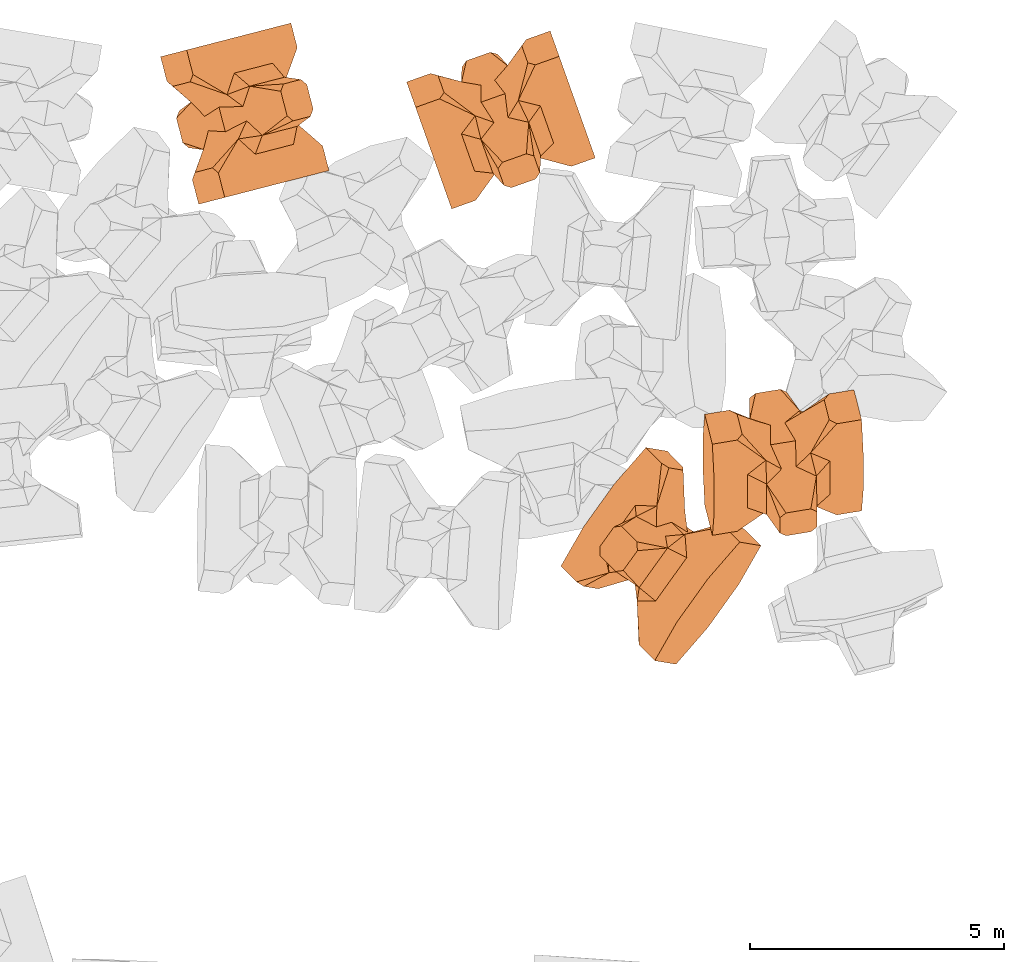
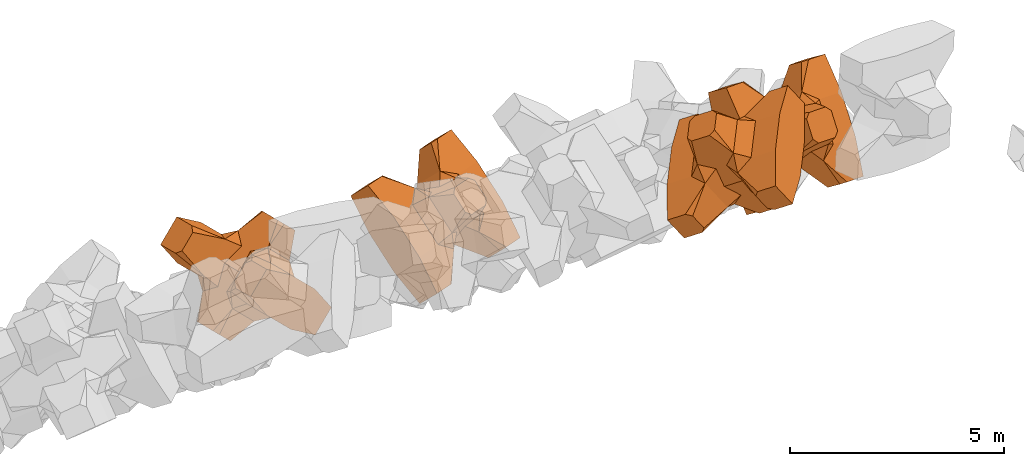
# One storey, part 15 of 17: 4 civil elements.
"""IFC4 building model written with IfcOpenShell, lengths in metres."""

import ifcopenshell
import ifcopenshell.guid

model = None  # the IFC model being written
_history = None  # IfcOwnerHistory: only IFC2X3 demands one
_inside = {}  # id of a spatial element -> (the spatial element, [elements in it])
_under = {}  # id of a project, library or spatial element -> (it, [spatial elements below it])
_declared = {}  # id of a project -> (the project, [libraries it declares])
_typed = {}  # id of a type object -> (the type object, [elements of that type])
_made_of = {}  # id of a material, layer set ... -> (it, [elements and type objects made of it])


def new_model(schema):
    """Start an empty IFC model of exactly this schema.

    Asked for "IFC4X3", IfcOpenShell would pick the latest addendum, in which some entities
    have other attributes; the version numbers below select the first issue.
    IFC2X3 requires an IfcOwnerHistory on every rooted entity: one is made here for all.
    """
    global model, _history
    if schema == "IFC4X3":
        model = ifcopenshell.file(schema_version=(4, 3, 0, 0))
    else:
        model = ifcopenshell.file(schema=schema)
    _inside.clear()
    _under.clear()
    _declared.clear()
    _typed.clear()
    _made_of.clear()
    _history = None
    if model.schema == "IFC2X3":
        org = make("IfcOrganization", Name="unknown")
        user = make(
            "IfcPersonAndOrganization",
            ThePerson=make("IfcPerson", FamilyName="unknown"),
            TheOrganization=org,
        )
        app = make(
            "IfcApplication",
            ApplicationDeveloper=org,
            Version="unknown",
            ApplicationFullName="unknown",
            ApplicationIdentifier="unknown",
        )
        _history = make(
            "IfcOwnerHistory",
            OwningUser=user,
            OwningApplication=app,
            ChangeAction="ADDED",
            CreationDate=0,
        )
    return model


def make(cls, **values):
    """One entity of the class cls with the attributes given. An attribute that is None is left unset."""
    return model.create_entity(
        cls, **{name: value for name, value in values.items() if value is not None}
    )


def entity(cls, *values):
    """Any entity or typed value of the class cls, its attributes in the order of the schema. None: left unset."""
    e = model.create_entity(cls)
    for i, value in enumerate(values):
        if value is not None:
            e[i] = value
    return e


def rooted(cls, **values):
    """An entity with a GlobalId (a new one), such as an element, a storey or a relation."""
    return make(cls, GlobalId=ifcopenshell.guid.new(), OwnerHistory=_history, **values)


def si_unit(unit_type, name, prefix=None):
    """IfcSIUnit, for example si_unit("LENGTHUNIT", "METRE", prefix="MILLI")."""
    return make("IfcSIUnit", UnitType=unit_type, Prefix=prefix, Name=name)


def converted_unit(unit_type, name, factor, base, dimensions=None, offset=None):
    """IfcConversionBasedUnit, such as the inch: factor (a typed value) times the base unit."""
    return make(
        "IfcConversionBasedUnit"
        if offset is None
        else "IfcConversionBasedUnitWithOffset",
        ConversionOffset=offset,
        Dimensions=None
        if dimensions is None
        else entity("IfcDimensionalExponents", *dimensions),
        UnitType=unit_type,
        Name=name,
        ConversionFactor=make(
            "IfcMeasureWithUnit", ValueComponent=factor, UnitComponent=base
        ),
    )


def assignment(units):
    """IfcUnitAssignment: the units of a project."""
    return None if units is None else make("IfcUnitAssignment", Units=units)


def point(xyz):
    """IfcCartesianPoint."""
    return None if xyz is None else make("IfcCartesianPoint", Coordinates=xyz)


def direction(xyz):
    """IfcDirection."""
    return None if xyz is None else make("IfcDirection", DirectionRatios=xyz)


def frame(location, z_axis=None, x_axis=None):
    """IfcAxis2Placement3D, a coordinate frame: its origin and axes. An axis left out is left unset."""
    return make(
        "IfcAxis2Placement3D",
        Location=point(location),
        Axis=direction(z_axis),
        RefDirection=direction(x_axis),
    )


def frame_2d(location, x_axis=None):
    """IfcAxis2Placement2D, a coordinate frame in the plane: its origin and x axis."""
    return make(
        "IfcAxis2Placement2D", Location=point(location), RefDirection=direction(x_axis)
    )


def origin_with_axes():
    """The frame at (0, 0, 0) with the z axis (0, 0, 1) and the x axis (1, 0, 0) written out."""
    return frame((0.0, 0.0, 0.0), z_axis=(0.0, 0.0, 1.0), x_axis=(1.0, 0.0, 0.0))


def origin_2d_with_axis():
    """The frame at (0, 0) in the plane with the x axis (1, 0) written out."""
    return frame_2d((0.0, 0.0), x_axis=(1.0, 0.0))


def place(relative_to, where):
    """IfcLocalPlacement: puts the frame where relative to a parent placement (None: the world)."""
    return make(
        "IfcLocalPlacement", PlacementRelTo=relative_to, RelativePlacement=where
    )


def context(
    kind, dimensions, precision=None, world=None, true_north=None, identifier=None
):
    """IfcGeometricRepresentationContext, for example the 3D "Model" context."""
    return make(
        "IfcGeometricRepresentationContext",
        ContextIdentifier=identifier,
        ContextType=kind,
        CoordinateSpaceDimension=dimensions,
        Precision=precision,
        WorldCoordinateSystem=world,
        TrueNorth=true_north,
    )


def subcontext(parent, identifier, kind, view, scale=None):
    """IfcGeometricRepresentationSubContext, for example "Body" below "Model"."""
    return make(
        "IfcGeometricRepresentationSubContext",
        ContextIdentifier=identifier,
        ContextType=kind,
        ParentContext=parent,
        TargetScale=scale,
        TargetView=view,
    )


def project(units=None, contexts=None):
    """IfcProject with its units and contexts."""
    return rooted(
        "IfcProject",
        Name="project",
        RepresentationContexts=contexts,
        UnitsInContext=assignment(units),
    )


def spatial(cls, under=None, at=None, **own):
    """A site, building, storey or space (cls), placed at a placement, below another one or the project."""
    s = rooted(cls, ObjectPlacement=at, **own)
    if under is not None:
        _under.setdefault(under.id(), (under, []))[1].append(s)
    return s


def point_list(points):
    """IfcCartesianPointList2D or 3D."""
    cls = (
        "IfcCartesianPointList2D" if len(points[0]) == 2 else "IfcCartesianPointList3D"
    )
    return make(cls, CoordList=points)


def polygons(points, faces, closed=None, point_numbers=None):
    """IfcPolygonalFaceSet: a face is its outer loop, then its inner loops; points numbered from 1."""
    made = []
    for loops in faces:
        if len(loops) == 1:
            made.append(make("IfcIndexedPolygonalFace", CoordIndex=loops[0]))
        else:
            made.append(
                make(
                    "IfcIndexedPolygonalFaceWithVoids",
                    CoordIndex=loops[0],
                    InnerCoordIndices=loops[1:],
                )
            )
    return make(
        "IfcPolygonalFaceSet",
        Coordinates=point_list(points),
        Closed=closed,
        Faces=made,
        PnIndex=point_numbers,
    )


def shape(context_of_items, identifier, shape_type, items):
    """IfcShapeRepresentation: the items that make up one representation, for example the "Body"."""
    return make(
        "IfcShapeRepresentation",
        ContextOfItems=context_of_items,
        RepresentationIdentifier=identifier,
        RepresentationType=shape_type,
        Items=items,
    )


def made_of(thing, what):
    """Note that an element or type object is made of a material, layer set ...; save() writes the relation."""
    if what is not None:
        _made_of.setdefault(what.id(), (what, []))[1].append(thing)
    return thing


def element(
    cls,
    number,
    at=None,
    inside=None,
    cuts=None,
    type_object=None,
    material=None,
    context=None,
    identifier="Body",
    shape_type=None,
    held_by="IfcProductDefinitionShape",
    body=None,
    shapes=None,
    **own,
):
    """One element of the class cls, such as IfcWall. Its Tag is "e" and its number.

    at: its placement. inside: the storey or other place that contains it. cuts: it is an
    opening in that element (IfcRelVoidsElement). A single representation is given by context,
    identifier, shape_type and body (its items); several are given by shapes. held_by: the class
    of the entity that holds the representations. save() writes the other relations.
    """
    e = rooted(cls, Tag="e%d" % number, ObjectPlacement=at, **own)
    if body is not None:
        shapes = [shape(context, identifier, shape_type, body)]
    if shapes is not None:
        e.Representation = make(held_by, Representations=shapes)
    if inside is not None:
        _inside.setdefault(inside.id(), (inside, []))[1].append(e)
    if cuts is not None:
        rooted(
            "IfcRelVoidsElement", RelatingBuildingElement=cuts, RelatedOpeningElement=e
        )
    if type_object is not None:
        _typed.setdefault(type_object.id(), (type_object, []))[1].append(e)
    return made_of(e, material)


def aggregate(whole, parts):
    """IfcRelAggregates: a whole, such as a stair, and the parts it consists of."""
    return rooted("IfcRelAggregates", RelatingObject=whole, RelatedObjects=parts)


def save(model, path):
    """Write the relations noted so far, then the file.

    IfcRelAggregates (storeys below a building ...), IfcRelContainedInSpatialStructure (elements
    in a storey), IfcRelDefinesByType, IfcRelAssociatesMaterial and IfcRelDeclares: one each for
    every whole, place, type object, material and project.
    """
    for whole, parts in _under.values():
        aggregate(whole, parts)
    for where, things in _inside.values():
        rooted(
            "IfcRelContainedInSpatialStructure",
            RelatedElements=things,
            RelatingStructure=where,
        )
    for kind, things in _typed.values():
        rooted("IfcRelDefinesByType", RelatedObjects=things, RelatingType=kind)
    for what, things in _made_of.values():
        rooted("IfcRelAssociatesMaterial", RelatedObjects=things, RelatingMaterial=what)
    for by, libraries in _declared.values():
        rooted("IfcRelDeclares", RelatingContext=by, RelatedDefinitions=libraries)
    model.write(path)


model = new_model("IFC4")

# Units and contexts
model_context = context("Model", 3, precision=1e-05, world=origin_with_axes())
plan_context = context("Plan", 2, precision=1e-05, world=origin_2d_with_axis())
body_context = subcontext(model_context, "Body", "Model", "MODEL_VIEW")
ifc_project = project(units=[si_unit("VOLUMEUNIT", "CUBIC_METRE"), si_unit("LENGTHUNIT", "METRE"), converted_unit("PLANEANGLEUNIT", "degree", entity("IfcReal", 0.0174532925199433), si_unit("PLANEANGLEUNIT", "RADIAN"), dimensions=[0, 0, 0, 0, 0, 0, 0]), si_unit("AREAUNIT", "SQUARE_METRE")], contexts=[model_context, plan_context])

# Site, building, storey
site_placement = place(None, origin_with_axes())
site = spatial("IfcSite", under=ifc_project, at=site_placement)
building_placement = place(site_placement, origin_with_axes())
building = spatial("IfcBuilding", under=site, at=building_placement, Name="Building")
storey_placement = place(building_placement, origin_with_axes())
storey = spatial("IfcBuildingStorey", under=building, at=storey_placement, Name="Storey")

# Civil elements
civil_element_1_placement = place(storey_placement, frame((10.4980764389038, 20.5367698669434, 2.36640000343323), z_axis=(-0.685017216108245, -0.176812213537438, -0.706745254514879), x_axis=(-0.684317272957764, -0.176631565261449, 0.707468133618003)))
element("IfcCivilElement", 1, at=civil_element_1_placement, inside=storey, ObjectType="IfcCivilElementType", context=body_context, shape_type="Tessellation", body=[
    polygons([(0.50000011920929, 0.500000059604645, 0.821428656578064), (0.374999821186066, 0.249999940395355, 1.5), (0.550000011920929, 0.145680621266365, 0.550000071525574), (0.374999821186066, -0.250000029802322, 1.5), (0.651315808296204, -0.250000029802322, 1.45970545872842e-07), (0.651315808296204, 0.249999940395355, 1.45970545872842e-07), (0.550000011920929, -0.145680695772171, 0.550000071525574), (0.50000011920929, -0.500000059604645, 0.821428656578064), (-0.25, 0.374999791383743, 1.5), (0.249999970197678, 0.374999791383743, 1.5), (-0.500000059604645, 0.500000059604645, 0.821428656578064), (-0.550000011920929, 0.824999988079071, 0.550000071525574), (0.550000011920929, 0.824999988079071, 0.550000071525574), (-0.550000011920929, 1.5, 0.550000071525574), (0.550000011920929, 1.5, 0.550000071525574), (-0.25, -0.375, 1.5), (0.249999970197678, -0.375, 1.5), (-0.374999970197678, -0.250000029802322, 1.5), (-0.374999970197678, 0.249999940395355, 1.5), (1.5, 0.87499988079071, -0.249999806284904), (1.5, 0.87499988079071, 0.25000011920929), (0.845557510852814, 0.449999898672104, -0.495555102825165), (0.845557510852814, 0.449999898672104, 0.495555102825165), (1.5, 1.5, -0.374999791383743), (1.5, 1.5, 0.374999940395355), (1.5, 1.0, -0.374999791383743), (1.5, 1.0, 0.374999940395355), (-1.5, 1.5, -0.374999791383743), (-1.5, 1.5, 0.374999940395355), (-0.550000011920929, 1.5, -0.54999977350235), (0.550000011920929, 1.5, -0.54999977350235), (0.550000011920929, 0.145680621266365, -0.54999977350235), (-0.500000059604645, -0.500000059604645, 0.821428656578064), (-0.550000011920929, -0.145680695772171, 0.550000071525574), (-0.651315808296204, 0.249999940395355, 1.45970545872842e-07), (-0.651315808296204, -0.250000029802322, 1.45970545872842e-07), (-0.550000011920929, 0.145680621266365, 0.550000071525574), (-1.5, 0.87499988079071, 0.25000011920929), (-1.5, 0.87499988079071, -0.249999806284904), (-0.845557391643524, 0.449999898672104, 0.495555102825165), (-0.845557391643524, 0.449999898672104, -0.495555102825165), (-1.5, 1.0, 0.374999940395355), (-1.5, 1.0, -0.374999791383743), (-0.550000011920929, 0.145680621266365, -0.54999977350235), (0.550000011920929, -0.825000107288361, 0.550000071525574), (-0.550000011920929, -0.825000107288361, 0.550000071525574), (0.550000011920929, -1.5, 0.550000071525574), (-0.550000011920929, -1.5, 0.550000071525574), (1.5, -0.875000059604645, 0.25000011920929), (1.5, -0.875000059604645, -0.249999806284904), (0.845557510852814, -0.450000137090683, 0.495555102825165), (0.845557510852814, -0.450000137090683, -0.495555102825165), (1.5, -1.5, 0.374999940395355), (1.5, -1.5, -0.374999791383743), (1.5, -1.00000011920929, 0.374999940395355), (1.5, -1.00000011920929, -0.374999791383743), (0.550000011920929, -1.5, -0.54999977350235), (-0.550000011920929, -1.5, -0.54999977350235), (-1.5, -1.5, -0.374999791383743), (-1.5, -1.5, 0.374999940395355), (0.550000011920929, -0.145680695772171, -0.54999977350235), (-1.5, -0.875000059604645, -0.249999806284904), (-1.5, -0.875000059604645, 0.25000011920929), (-0.845557391643524, -0.450000137090683, -0.495555102825165), (-0.845557391643524, -0.450000137090683, 0.495555102825165), (-1.5, -1.00000011920929, -0.374999791383743), (-1.5, -1.00000011920929, 0.374999940395355), (-0.550000011920929, -0.145680695772171, -0.54999977350235), (0.50000011920929, -0.500000059604645, -0.821428418159485), (0.374999821186066, -0.250000029802322, -1.49999976158142), (0.374999821186066, 0.249999940395355, -1.49999976158142), (0.50000011920929, 0.500000059604645, -0.821428418159485), (0.249999970197678, 0.374999791383743, -1.49999976158142), (-0.25, 0.374999791383743, -1.49999976158142), (-0.500000059604645, 0.500000059604645, -0.821428418159485), (0.550000011920929, 0.824999988079071, -0.54999977350235), (-0.550000011920929, 0.824999988079071, -0.54999977350235), (0.249999970197678, -0.375, -1.49999976158142), (-0.25, -0.375, -1.49999976158142), (-0.374999970197678, -0.250000029802322, -1.49999976158142), (-0.374999970197678, 0.249999940395355, -1.49999976158142), (-0.500000059604645, -0.500000059604645, -0.821428418159485), (-0.550000011920929, -0.825000107288361, -0.54999977350235), (0.550000011920929, -0.825000107288361, -0.54999977350235)], [[[1, 2, 3]], [[3, 2, 4]], [[5, 6, 7]], [[7, 6, 3]], [[7, 3, 8]], [[8, 3, 4]], [[9, 10, 11]], [[11, 10, 1]], [[12, 13, 14]], [[14, 13, 15]], [[16, 17, 18]], [[18, 17, 4]], [[18, 4, 19]], [[19, 4, 2]], [[19, 2, 9]], [[9, 2, 10]], [[20, 21, 22]], [[22, 21, 23]], [[24, 25, 26]], [[26, 25, 27]], [[26, 27, 20]], [[20, 27, 21]], [[23, 27, 13]], [[13, 27, 25]], [[13, 25, 15]], [[28, 29, 30]], [[30, 29, 14]], [[30, 14, 31]], [[31, 14, 15]], [[31, 15, 24]], [[24, 15, 25]], [[21, 27, 23]], [[2, 1, 10]], [[13, 12, 1]], [[1, 12, 11]], [[13, 1, 23]], [[32, 22, 6]], [[6, 22, 23]], [[6, 23, 3]], [[3, 23, 1]], [[33, 18, 34]], [[34, 18, 19]], [[35, 36, 37]], [[37, 36, 34]], [[37, 34, 11]], [[11, 34, 19]], [[38, 39, 40]], [[40, 39, 41]], [[29, 28, 42]], [[42, 28, 43]], [[42, 43, 38]], [[38, 43, 39]], [[14, 29, 12]], [[12, 29, 42]], [[12, 42, 40]], [[40, 42, 38]], [[9, 11, 19]], [[40, 11, 12]], [[37, 40, 35]], [[35, 40, 41]], [[35, 41, 44]], [[11, 40, 37]], [[17, 16, 8]], [[8, 16, 33]], [[45, 46, 47]], [[47, 46, 48]], [[49, 50, 51]], [[51, 50, 52]], [[53, 54, 55]], [[55, 54, 56]], [[55, 56, 49]], [[49, 56, 50]], [[47, 53, 45]], [[45, 53, 55]], [[45, 55, 51]], [[54, 53, 57]], [[57, 53, 47]], [[57, 47, 58]], [[58, 47, 48]], [[58, 48, 59]], [[59, 48, 60]], [[51, 55, 49]], [[17, 8, 4]], [[46, 45, 33]], [[33, 45, 8]], [[51, 8, 45]], [[7, 51, 5]], [[5, 51, 52]], [[5, 52, 61]], [[8, 51, 7]], [[62, 63, 64]], [[64, 63, 65]], [[59, 60, 66]], [[66, 60, 67]], [[66, 67, 62]], [[62, 67, 63]], [[65, 67, 46]], [[46, 67, 60]], [[46, 60, 48]], [[63, 67, 65]], [[18, 33, 16]], [[46, 33, 65]], [[68, 64, 36]], [[36, 64, 65]], [[36, 65, 34]], [[34, 65, 33]], [[69, 70, 61]], [[61, 70, 71]], [[6, 5, 32]], [[32, 5, 61]], [[32, 61, 72]], [[72, 61, 71]], [[73, 74, 72]], [[72, 74, 75]], [[76, 77, 31]], [[31, 77, 30]], [[78, 79, 70]], [[70, 79, 80]], [[70, 80, 71]], [[71, 80, 81]], [[71, 81, 73]], [[73, 81, 74]], [[31, 24, 76]], [[76, 24, 26]], [[76, 26, 22]], [[22, 26, 20]], [[73, 72, 71]], [[77, 76, 75]], [[75, 76, 72]], [[22, 72, 76]], [[72, 22, 32]], [[75, 81, 44]], [[44, 81, 80]], [[36, 35, 68]], [[68, 35, 44]], [[68, 44, 82]], [[82, 44, 80]], [[41, 43, 77]], [[77, 43, 28]], [[77, 28, 30]], [[39, 43, 41]], [[81, 75, 74]], [[77, 75, 41]], [[44, 41, 75]], [[79, 78, 82]], [[82, 78, 69]], [[83, 84, 58]], [[58, 84, 57]], [[52, 56, 84]], [[84, 56, 54]], [[84, 54, 57]], [[50, 56, 52]], [[70, 69, 78]], [[84, 83, 69]], [[69, 83, 82]], [[84, 69, 52]], [[61, 52, 69]], [[58, 59, 83]], [[83, 59, 66]], [[83, 66, 64]], [[64, 66, 62]], [[79, 82, 80]], [[64, 82, 83]], [[82, 64, 68]]], closed=True),
])
civil_element_2_placement = place(storey_placement, frame((15.54172706604, 20.4129734039307, 2.36600804328918), z_axis=(-0.236642717340613, 0.666333434221933, -0.707106766173013), x_axis=(-0.236642745474011, 0.666333429522614, 0.707106761186141)))
element("IfcCivilElement", 2, at=civil_element_2_placement, inside=storey, ObjectType="IfcCivilElementType", context=body_context, shape_type="Tessellation", body=[
    polygons([(0.50000011920929, 0.500000059604645, 0.821428835391998), (0.374999821186066, 0.249999940395355, 1.50000035762787), (0.550000011920929, 0.145680621266365, 0.550000190734863), (0.374999821186066, -0.250000029802322, 1.50000035762787), (0.651315808296204, -0.250000029802322, 1.45970574294552e-07), (0.651315808296204, 0.249999940395355, 1.45970574294552e-07), (0.550000011920929, -0.145680695772171, 0.550000190734863), (0.50000011920929, -0.500000059604645, 0.821428835391998), (-0.25, 0.374999791383743, 1.50000035762787), (0.249999970197678, 0.374999791383743, 1.50000035762787), (-0.500000059604645, 0.500000059604645, 0.821428835391998), (-0.550000011920929, 0.824999988079071, 0.550000190734863), (0.550000011920929, 0.824999988079071, 0.550000190734863), (-0.550000011920929, 1.5, 0.550000190734863), (0.550000011920929, 1.5, 0.550000190734863), (-0.25, -0.375, 1.50000035762787), (0.249999970197678, -0.375, 1.50000035762787), (-0.374999970197678, -0.250000029802322, 1.50000035762787), (-0.374999970197678, 0.249999940395355, 1.50000035762787), (1.5, 0.87499988079071, -0.249999865889549), (1.5, 0.87499988079071, 0.250000149011612), (0.845557510852814, 0.449999898672104, -0.495555222034454), (0.845557510852814, 0.449999898672104, 0.495555222034454), (1.5, 1.5, -0.374999850988388), (1.5, 1.5, 0.375), (1.5, 1.0, -0.374999850988388), (1.5, 1.0, 0.375), (-1.5, 1.5, -0.374999850988388), (-1.5, 1.5, 0.375), (-0.550000011920929, 1.5, -0.549999892711639), (0.550000011920929, 1.5, -0.549999892711639), (0.550000011920929, 0.145680621266365, -0.549999892711639), (-0.500000059604645, -0.500000059604645, 0.821428835391998), (-0.550000011920929, -0.145680695772171, 0.550000190734863), (-0.651315808296204, 0.249999940395355, 1.45970574294552e-07), (-0.651315808296204, -0.250000029802322, 1.45970574294552e-07), (-0.550000011920929, 0.145680621266365, 0.550000190734863), (-1.5, 0.87499988079071, 0.250000149011612), (-1.5, 0.87499988079071, -0.249999865889549), (-0.845557391643524, 0.449999898672104, 0.495555222034454), (-0.845557391643524, 0.449999898672104, -0.495555222034454), (-1.5, 1.0, 0.375), (-1.5, 1.0, -0.374999850988388), (-0.550000011920929, 0.145680621266365, -0.549999892711639), (0.550000011920929, -0.825000107288361, 0.550000190734863), (-0.550000011920929, -0.825000107288361, 0.550000190734863), (0.550000011920929, -1.5, 0.550000190734863), (-0.550000011920929, -1.5, 0.550000190734863), (1.5, -0.875000059604645, 0.250000149011612), (1.5, -0.875000059604645, -0.249999865889549), (0.845557510852814, -0.450000137090683, 0.495555222034454), (0.845557510852814, -0.450000137090683, -0.495555222034454), (1.5, -1.5, 0.375), (1.5, -1.5, -0.374999850988388), (1.5, -1.00000011920929, 0.375), (1.5, -1.00000011920929, -0.374999850988388), (0.550000011920929, -1.5, -0.549999892711639), (-0.550000011920929, -1.5, -0.549999892711639), (-1.5, -1.5, -0.374999850988388), (-1.5, -1.5, 0.375), (0.550000011920929, -0.145680695772171, -0.549999892711639), (-1.5, -0.875000059604645, -0.249999865889549), (-1.5, -0.875000059604645, 0.250000149011612), (-0.845557391643524, -0.450000137090683, -0.495555222034454), (-0.845557391643524, -0.450000137090683, 0.495555222034454), (-1.5, -1.00000011920929, -0.374999850988388), (-1.5, -1.00000011920929, 0.375), (-0.550000011920929, -0.145680695772171, -0.549999892711639), (0.50000011920929, -0.500000059604645, -0.821428596973419), (0.374999821186066, -0.250000029802322, -1.5), (0.374999821186066, 0.249999940395355, -1.5), (0.50000011920929, 0.500000059604645, -0.821428596973419), (0.249999970197678, 0.374999791383743, -1.5), (-0.25, 0.374999791383743, -1.5), (-0.500000059604645, 0.500000059604645, -0.821428596973419), (0.550000011920929, 0.824999988079071, -0.549999892711639), (-0.550000011920929, 0.824999988079071, -0.549999892711639), (0.249999970197678, -0.375, -1.5), (-0.25, -0.375, -1.5), (-0.374999970197678, -0.250000029802322, -1.5), (-0.374999970197678, 0.249999940395355, -1.5), (-0.500000059604645, -0.500000059604645, -0.821428596973419), (-0.550000011920929, -0.825000107288361, -0.549999892711639), (0.550000011920929, -0.825000107288361, -0.549999892711639)], [[[1, 2, 3]], [[3, 2, 4]], [[5, 6, 7]], [[7, 6, 3]], [[7, 3, 8]], [[8, 3, 4]], [[9, 10, 11]], [[11, 10, 1]], [[12, 13, 14]], [[14, 13, 15]], [[16, 17, 18]], [[18, 17, 4]], [[18, 4, 19]], [[19, 4, 2]], [[19, 2, 9]], [[9, 2, 10]], [[20, 21, 22]], [[22, 21, 23]], [[24, 25, 26]], [[26, 25, 27]], [[26, 27, 20]], [[20, 27, 21]], [[23, 27, 13]], [[13, 27, 25]], [[13, 25, 15]], [[28, 29, 30]], [[30, 29, 14]], [[30, 14, 31]], [[31, 14, 15]], [[31, 15, 24]], [[24, 15, 25]], [[21, 27, 23]], [[2, 1, 10]], [[13, 12, 1]], [[1, 12, 11]], [[13, 1, 23]], [[32, 22, 6]], [[6, 22, 23]], [[6, 23, 3]], [[3, 23, 1]], [[33, 18, 34]], [[34, 18, 19]], [[35, 36, 37]], [[37, 36, 34]], [[37, 34, 11]], [[11, 34, 19]], [[38, 39, 40]], [[40, 39, 41]], [[29, 28, 42]], [[42, 28, 43]], [[42, 43, 38]], [[38, 43, 39]], [[14, 29, 12]], [[12, 29, 42]], [[12, 42, 40]], [[40, 42, 38]], [[9, 11, 19]], [[40, 11, 12]], [[37, 40, 35]], [[35, 40, 41]], [[35, 41, 44]], [[11, 40, 37]], [[17, 16, 8]], [[8, 16, 33]], [[45, 46, 47]], [[47, 46, 48]], [[49, 50, 51]], [[51, 50, 52]], [[53, 54, 55]], [[55, 54, 56]], [[55, 56, 49]], [[49, 56, 50]], [[47, 53, 45]], [[45, 53, 55]], [[45, 55, 51]], [[54, 53, 57]], [[57, 53, 47]], [[57, 47, 58]], [[58, 47, 48]], [[58, 48, 59]], [[59, 48, 60]], [[51, 55, 49]], [[17, 8, 4]], [[46, 45, 33]], [[33, 45, 8]], [[51, 8, 45]], [[7, 51, 5]], [[5, 51, 52]], [[5, 52, 61]], [[8, 51, 7]], [[62, 63, 64]], [[64, 63, 65]], [[59, 60, 66]], [[66, 60, 67]], [[66, 67, 62]], [[62, 67, 63]], [[65, 67, 46]], [[46, 67, 60]], [[46, 60, 48]], [[63, 67, 65]], [[18, 33, 16]], [[46, 33, 65]], [[68, 64, 36]], [[36, 64, 65]], [[36, 65, 34]], [[34, 65, 33]], [[69, 70, 61]], [[61, 70, 71]], [[6, 5, 32]], [[32, 5, 61]], [[32, 61, 72]], [[72, 61, 71]], [[73, 74, 72]], [[72, 74, 75]], [[76, 77, 31]], [[31, 77, 30]], [[78, 79, 70]], [[70, 79, 80]], [[70, 80, 71]], [[71, 80, 81]], [[71, 81, 73]], [[73, 81, 74]], [[31, 24, 76]], [[76, 24, 26]], [[76, 26, 22]], [[22, 26, 20]], [[73, 72, 71]], [[77, 76, 75]], [[75, 76, 72]], [[22, 72, 76]], [[72, 22, 32]], [[75, 81, 44]], [[44, 81, 80]], [[36, 35, 68]], [[68, 35, 44]], [[68, 44, 82]], [[82, 44, 80]], [[41, 43, 77]], [[77, 43, 28]], [[77, 28, 30]], [[39, 43, 41]], [[81, 75, 74]], [[77, 75, 41]], [[44, 41, 75]], [[79, 78, 82]], [[82, 78, 69]], [[83, 84, 58]], [[58, 84, 57]], [[52, 56, 84]], [[84, 56, 54]], [[84, 54, 57]], [[50, 56, 52]], [[70, 69, 78]], [[84, 83, 69]], [[69, 83, 82]], [[84, 69, 52]], [[61, 52, 69]], [[58, 59, 83]], [[83, 59, 66]], [[83, 66, 64]], [[64, 66, 62]], [[79, 82, 80]], [[64, 82, 83]], [[82, 64, 68]]], closed=True),
])
civil_element_3_placement = place(storey_placement, frame((21.0991554260254, 13.6667041778564, 6.85630750656128), z_axis=(0.200235944692501, -0.784821199459041, 0.586482098049696), x_axis=(0.000403537567733012, -0.598539124745671, -0.80109347351362)))
element("IfcCivilElement", 3, at=civil_element_3_placement, inside=storey, ObjectType="IfcCivilElementType", context=body_context, shape_type="Tessellation", body=[
    polygons([(0.50000011920929, 0.500000059604645, 0.821428716182709), (0.374999821186066, 0.249999940395355, 1.50000023841858), (0.550000011920929, 0.145680621266365, 0.550000131130219), (0.374999821186066, -0.250000029802322, 1.50000023841858), (0.651315808296204, -0.250000029802322, 1.45970560083697e-07), (0.651315808296204, 0.249999940395355, 1.45970560083697e-07), (0.550000011920929, -0.145680695772171, 0.550000131130219), (0.50000011920929, -0.500000059604645, 0.821428716182709), (-0.25, 0.374999791383743, 1.50000023841858), (0.249999970197678, 0.374999791383743, 1.50000023841858), (-0.500000059604645, 0.500000059604645, 0.821428716182709), (-0.550000011920929, 0.824999988079071, 0.550000131130219), (0.550000011920929, 0.824999988079071, 0.550000131130219), (-0.550000011920929, 1.5, 0.550000131130219), (0.550000011920929, 1.5, 0.550000131130219), (-0.25, -0.375, 1.50000023841858), (0.249999970197678, -0.375, 1.50000023841858), (-0.374999970197678, -0.250000029802322, 1.50000023841858), (-0.374999970197678, 0.249999940395355, 1.50000023841858), (1.5, 0.87499988079071, -0.249999836087227), (1.5, 0.87499988079071, 0.25000011920929), (0.845557510852814, 0.449999898672104, -0.49555516242981), (0.845557510852814, 0.449999898672104, 0.49555516242981), (1.5, 1.5, -0.374999821186066), (1.5, 1.5, 0.374999970197678), (1.5, 1.0, -0.374999821186066), (1.5, 1.0, 0.374999970197678), (-1.5, 1.5, -0.374999821186066), (-1.5, 1.5, 0.374999970197678), (-0.550000011920929, 1.5, -0.549999833106995), (0.550000011920929, 1.5, -0.549999833106995), (0.550000011920929, 0.145680621266365, -0.549999833106995), (-0.500000059604645, -0.500000059604645, 0.821428716182709), (-0.550000011920929, -0.145680695772171, 0.550000131130219), (-0.651315808296204, 0.249999940395355, 1.45970560083697e-07), (-0.651315808296204, -0.250000029802322, 1.45970560083697e-07), (-0.550000011920929, 0.145680621266365, 0.550000131130219), (-1.5, 0.87499988079071, 0.25000011920929), (-1.5, 0.87499988079071, -0.249999836087227), (-0.845557391643524, 0.449999898672104, 0.49555516242981), (-0.845557391643524, 0.449999898672104, -0.49555516242981), (-1.5, 1.0, 0.374999970197678), (-1.5, 1.0, -0.374999821186066), (-0.550000011920929, 0.145680621266365, -0.549999833106995), (0.550000011920929, -0.825000107288361, 0.550000131130219), (-0.550000011920929, -0.825000107288361, 0.550000131130219), (0.550000011920929, -1.5, 0.550000131130219), (-0.550000011920929, -1.5, 0.550000131130219), (1.5, -0.875000059604645, 0.25000011920929), (1.5, -0.875000059604645, -0.249999836087227), (0.845557510852814, -0.450000137090683, 0.49555516242981), (0.845557510852814, -0.450000137090683, -0.49555516242981), (1.5, -1.5, 0.374999970197678), (1.5, -1.5, -0.374999821186066), (1.5, -1.00000011920929, 0.374999970197678), (1.5, -1.00000011920929, -0.374999821186066), (0.550000011920929, -1.5, -0.549999833106995), (-0.550000011920929, -1.5, -0.549999833106995), (-1.5, -1.5, -0.374999821186066), (-1.5, -1.5, 0.374999970197678), (0.550000011920929, -0.145680695772171, -0.549999833106995), (-1.5, -0.875000059604645, -0.249999836087227), (-1.5, -0.875000059604645, 0.25000011920929), (-0.845557391643524, -0.450000137090683, -0.49555516242981), (-0.845557391643524, -0.450000137090683, 0.49555516242981), (-1.5, -1.00000011920929, -0.374999821186066), (-1.5, -1.00000011920929, 0.374999970197678), (-0.550000011920929, -0.145680695772171, -0.549999833106995), (0.50000011920929, -0.500000059604645, -0.821428537368774), (0.374999821186066, -0.250000029802322, -1.49999988079071), (0.374999821186066, 0.249999940395355, -1.49999988079071), (0.50000011920929, 0.500000059604645, -0.821428537368774), (0.249999970197678, 0.374999791383743, -1.49999988079071), (-0.25, 0.374999791383743, -1.49999988079071), (-0.500000059604645, 0.500000059604645, -0.821428537368774), (0.550000011920929, 0.824999988079071, -0.549999833106995), (-0.550000011920929, 0.824999988079071, -0.549999833106995), (0.249999970197678, -0.375, -1.49999988079071), (-0.25, -0.375, -1.49999988079071), (-0.374999970197678, -0.250000029802322, -1.49999988079071), (-0.374999970197678, 0.249999940395355, -1.49999988079071), (-0.500000059604645, -0.500000059604645, -0.821428537368774), (-0.550000011920929, -0.825000107288361, -0.549999833106995), (0.550000011920929, -0.825000107288361, -0.549999833106995)], [[[1, 2, 3]], [[3, 2, 4]], [[5, 6, 7]], [[7, 6, 3]], [[7, 3, 8]], [[8, 3, 4]], [[9, 10, 11]], [[11, 10, 1]], [[12, 13, 14]], [[14, 13, 15]], [[16, 17, 18]], [[18, 17, 4]], [[18, 4, 19]], [[19, 4, 2]], [[19, 2, 9]], [[9, 2, 10]], [[20, 21, 22]], [[22, 21, 23]], [[24, 25, 26]], [[26, 25, 27]], [[26, 27, 20]], [[20, 27, 21]], [[23, 27, 13]], [[13, 27, 25]], [[13, 25, 15]], [[28, 29, 30]], [[30, 29, 14]], [[30, 14, 31]], [[31, 14, 15]], [[31, 15, 24]], [[24, 15, 25]], [[21, 27, 23]], [[2, 1, 10]], [[13, 12, 1]], [[1, 12, 11]], [[13, 1, 23]], [[32, 22, 6]], [[6, 22, 23]], [[6, 23, 3]], [[3, 23, 1]], [[33, 18, 34]], [[34, 18, 19]], [[35, 36, 37]], [[37, 36, 34]], [[37, 34, 11]], [[11, 34, 19]], [[38, 39, 40]], [[40, 39, 41]], [[29, 28, 42]], [[42, 28, 43]], [[42, 43, 38]], [[38, 43, 39]], [[14, 29, 12]], [[12, 29, 42]], [[12, 42, 40]], [[40, 42, 38]], [[9, 11, 19]], [[40, 11, 12]], [[37, 40, 35]], [[35, 40, 41]], [[35, 41, 44]], [[11, 40, 37]], [[17, 16, 8]], [[8, 16, 33]], [[45, 46, 47]], [[47, 46, 48]], [[49, 50, 51]], [[51, 50, 52]], [[53, 54, 55]], [[55, 54, 56]], [[55, 56, 49]], [[49, 56, 50]], [[47, 53, 45]], [[45, 53, 55]], [[45, 55, 51]], [[54, 53, 57]], [[57, 53, 47]], [[57, 47, 58]], [[58, 47, 48]], [[58, 48, 59]], [[59, 48, 60]], [[51, 55, 49]], [[17, 8, 4]], [[46, 45, 33]], [[33, 45, 8]], [[51, 8, 45]], [[7, 51, 5]], [[5, 51, 52]], [[5, 52, 61]], [[8, 51, 7]], [[62, 63, 64]], [[64, 63, 65]], [[59, 60, 66]], [[66, 60, 67]], [[66, 67, 62]], [[62, 67, 63]], [[65, 67, 46]], [[46, 67, 60]], [[46, 60, 48]], [[63, 67, 65]], [[18, 33, 16]], [[46, 33, 65]], [[68, 64, 36]], [[36, 64, 65]], [[36, 65, 34]], [[34, 65, 33]], [[69, 70, 61]], [[61, 70, 71]], [[6, 5, 32]], [[32, 5, 61]], [[32, 61, 72]], [[72, 61, 71]], [[73, 74, 72]], [[72, 74, 75]], [[76, 77, 31]], [[31, 77, 30]], [[78, 79, 70]], [[70, 79, 80]], [[70, 80, 71]], [[71, 80, 81]], [[71, 81, 73]], [[73, 81, 74]], [[31, 24, 76]], [[76, 24, 26]], [[76, 26, 22]], [[22, 26, 20]], [[73, 72, 71]], [[77, 76, 75]], [[75, 76, 72]], [[22, 72, 76]], [[72, 22, 32]], [[75, 81, 44]], [[44, 81, 80]], [[36, 35, 68]], [[68, 35, 44]], [[68, 44, 82]], [[82, 44, 80]], [[41, 43, 77]], [[77, 43, 28]], [[77, 28, 30]], [[39, 43, 41]], [[81, 75, 74]], [[77, 75, 41]], [[44, 41, 75]], [[79, 78, 82]], [[82, 78, 69]], [[83, 84, 58]], [[58, 84, 57]], [[52, 56, 84]], [[84, 56, 54]], [[84, 54, 57]], [[50, 56, 52]], [[70, 69, 78]], [[84, 83, 69]], [[69, 83, 82]], [[84, 69, 52]], [[61, 52, 69]], [[58, 59, 83]], [[83, 59, 66]], [[83, 66, 64]], [[64, 66, 62]], [[79, 82, 80]], [[64, 82, 83]], [[82, 64, 68]]], closed=True),
])
civil_element_4_placement = place(storey_placement, frame((18.692102432251, 11.8287315368652, 8.03323650360107), z_axis=(0.556407290602754, -0.0933929935150945, -0.825644400287673), x_axis=(-0.557797795290901, -0.778463490835729, -0.287847551673557)))
element("IfcCivilElement", 4, at=civil_element_4_placement, inside=storey, ObjectType="IfcCivilElementType", context=body_context, shape_type="Tessellation", body=[
    polygons([(0.50000011920929, 0.500000059604645, 0.821428835391998), (0.374999821186066, 0.249999940395355, 1.50000035762787), (0.550000011920929, 0.145680621266365, 0.550000190734863), (0.374999821186066, -0.250000029802322, 1.50000035762787), (0.651315808296204, -0.250000029802322, 1.45970574294552e-07), (0.651315808296204, 0.249999940395355, 1.45970574294552e-07), (0.550000011920929, -0.145680695772171, 0.550000190734863), (0.50000011920929, -0.500000059604645, 0.821428835391998), (-0.25, 0.374999791383743, 1.50000035762787), (0.249999970197678, 0.374999791383743, 1.50000035762787), (-0.500000059604645, 0.500000059604645, 0.821428835391998), (-0.550000011920929, 0.824999988079071, 0.550000190734863), (0.550000011920929, 0.824999988079071, 0.550000190734863), (-0.550000011920929, 1.5, 0.550000190734863), (0.550000011920929, 1.5, 0.550000190734863), (-0.25, -0.375, 1.50000035762787), (0.249999970197678, -0.375, 1.50000035762787), (-0.374999970197678, -0.250000029802322, 1.50000035762787), (-0.374999970197678, 0.249999940395355, 1.50000035762787), (1.5, 0.87499988079071, -0.249999865889549), (1.5, 0.87499988079071, 0.250000149011612), (0.845557510852814, 0.449999898672104, -0.495555222034454), (0.845557510852814, 0.449999898672104, 0.495555222034454), (1.5, 1.5, -0.374999850988388), (1.5, 1.5, 0.375), (1.5, 1.0, -0.374999850988388), (1.5, 1.0, 0.375), (-1.5, 1.5, -0.374999850988388), (-1.5, 1.5, 0.375), (-0.550000011920929, 1.5, -0.549999892711639), (0.550000011920929, 1.5, -0.549999892711639), (0.550000011920929, 0.145680621266365, -0.549999892711639), (-0.500000059604645, -0.500000059604645, 0.821428835391998), (-0.550000011920929, -0.145680695772171, 0.550000190734863), (-0.651315808296204, 0.249999940395355, 1.45970574294552e-07), (-0.651315808296204, -0.250000029802322, 1.45970574294552e-07), (-0.550000011920929, 0.145680621266365, 0.550000190734863), (-1.5, 0.87499988079071, 0.250000149011612), (-1.5, 0.87499988079071, -0.249999865889549), (-0.845557391643524, 0.449999898672104, 0.495555222034454), (-0.845557391643524, 0.449999898672104, -0.495555222034454), (-1.5, 1.0, 0.375), (-1.5, 1.0, -0.374999850988388), (-0.550000011920929, 0.145680621266365, -0.549999892711639), (0.550000011920929, -0.825000107288361, 0.550000190734863), (-0.550000011920929, -0.825000107288361, 0.550000190734863), (0.550000011920929, -1.5, 0.550000190734863), (-0.550000011920929, -1.5, 0.550000190734863), (1.5, -0.875000059604645, 0.250000149011612), (1.5, -0.875000059604645, -0.249999865889549), (0.845557510852814, -0.450000137090683, 0.495555222034454), (0.845557510852814, -0.450000137090683, -0.495555222034454), (1.5, -1.5, 0.375), (1.5, -1.5, -0.374999850988388), (1.5, -1.00000011920929, 0.375), (1.5, -1.00000011920929, -0.374999850988388), (0.550000011920929, -1.5, -0.549999892711639), (-0.550000011920929, -1.5, -0.549999892711639), (-1.5, -1.5, -0.374999850988388), (-1.5, -1.5, 0.375), (0.550000011920929, -0.145680695772171, -0.549999892711639), (-1.5, -0.875000059604645, -0.249999865889549), (-1.5, -0.875000059604645, 0.250000149011612), (-0.845557391643524, -0.450000137090683, -0.495555222034454), (-0.845557391643524, -0.450000137090683, 0.495555222034454), (-1.5, -1.00000011920929, -0.374999850988388), (-1.5, -1.00000011920929, 0.375), (-0.550000011920929, -0.145680695772171, -0.549999892711639), (0.50000011920929, -0.500000059604645, -0.821428596973419), (0.374999821186066, -0.250000029802322, -1.5), (0.374999821186066, 0.249999940395355, -1.5), (0.50000011920929, 0.500000059604645, -0.821428596973419), (0.249999970197678, 0.374999791383743, -1.5), (-0.25, 0.374999791383743, -1.5), (-0.500000059604645, 0.500000059604645, -0.821428596973419), (0.550000011920929, 0.824999988079071, -0.549999892711639), (-0.550000011920929, 0.824999988079071, -0.549999892711639), (0.249999970197678, -0.375, -1.5), (-0.25, -0.375, -1.5), (-0.374999970197678, -0.250000029802322, -1.5), (-0.374999970197678, 0.249999940395355, -1.5), (-0.500000059604645, -0.500000059604645, -0.821428596973419), (-0.550000011920929, -0.825000107288361, -0.549999892711639), (0.550000011920929, -0.825000107288361, -0.549999892711639)], [[[1, 2, 3]], [[3, 2, 4]], [[5, 6, 7]], [[7, 6, 3]], [[7, 3, 8]], [[8, 3, 4]], [[9, 10, 11]], [[11, 10, 1]], [[12, 13, 14]], [[14, 13, 15]], [[16, 17, 18]], [[18, 17, 4]], [[18, 4, 19]], [[19, 4, 2]], [[19, 2, 9]], [[9, 2, 10]], [[20, 21, 22]], [[22, 21, 23]], [[24, 25, 26]], [[26, 25, 27]], [[26, 27, 20]], [[20, 27, 21]], [[23, 27, 13]], [[13, 27, 25]], [[13, 25, 15]], [[28, 29, 30]], [[30, 29, 14]], [[30, 14, 31]], [[31, 14, 15]], [[31, 15, 24]], [[24, 15, 25]], [[21, 27, 23]], [[2, 1, 10]], [[13, 12, 1]], [[1, 12, 11]], [[13, 1, 23]], [[32, 22, 6]], [[6, 22, 23]], [[6, 23, 3]], [[3, 23, 1]], [[33, 18, 34]], [[34, 18, 19]], [[35, 36, 37]], [[37, 36, 34]], [[37, 34, 11]], [[11, 34, 19]], [[38, 39, 40]], [[40, 39, 41]], [[29, 28, 42]], [[42, 28, 43]], [[42, 43, 38]], [[38, 43, 39]], [[14, 29, 12]], [[12, 29, 42]], [[12, 42, 40]], [[40, 42, 38]], [[9, 11, 19]], [[40, 11, 12]], [[37, 40, 35]], [[35, 40, 41]], [[35, 41, 44]], [[11, 40, 37]], [[17, 16, 8]], [[8, 16, 33]], [[45, 46, 47]], [[47, 46, 48]], [[49, 50, 51]], [[51, 50, 52]], [[53, 54, 55]], [[55, 54, 56]], [[55, 56, 49]], [[49, 56, 50]], [[47, 53, 45]], [[45, 53, 55]], [[45, 55, 51]], [[54, 53, 57]], [[57, 53, 47]], [[57, 47, 58]], [[58, 47, 48]], [[58, 48, 59]], [[59, 48, 60]], [[51, 55, 49]], [[17, 8, 4]], [[46, 45, 33]], [[33, 45, 8]], [[51, 8, 45]], [[7, 51, 5]], [[5, 51, 52]], [[5, 52, 61]], [[8, 51, 7]], [[62, 63, 64]], [[64, 63, 65]], [[59, 60, 66]], [[66, 60, 67]], [[66, 67, 62]], [[62, 67, 63]], [[65, 67, 46]], [[46, 67, 60]], [[46, 60, 48]], [[63, 67, 65]], [[18, 33, 16]], [[46, 33, 65]], [[68, 64, 36]], [[36, 64, 65]], [[36, 65, 34]], [[34, 65, 33]], [[69, 70, 61]], [[61, 70, 71]], [[6, 5, 32]], [[32, 5, 61]], [[32, 61, 72]], [[72, 61, 71]], [[73, 74, 72]], [[72, 74, 75]], [[76, 77, 31]], [[31, 77, 30]], [[78, 79, 70]], [[70, 79, 80]], [[70, 80, 71]], [[71, 80, 81]], [[71, 81, 73]], [[73, 81, 74]], [[31, 24, 76]], [[76, 24, 26]], [[76, 26, 22]], [[22, 26, 20]], [[73, 72, 71]], [[77, 76, 75]], [[75, 76, 72]], [[22, 72, 76]], [[72, 22, 32]], [[75, 81, 44]], [[44, 81, 80]], [[36, 35, 68]], [[68, 35, 44]], [[68, 44, 82]], [[82, 44, 80]], [[41, 43, 77]], [[77, 43, 28]], [[77, 28, 30]], [[39, 43, 41]], [[81, 75, 74]], [[77, 75, 41]], [[44, 41, 75]], [[79, 78, 82]], [[82, 78, 69]], [[83, 84, 58]], [[58, 84, 57]], [[52, 56, 84]], [[84, 56, 54]], [[84, 54, 57]], [[50, 56, 52]], [[70, 69, 78]], [[84, 83, 69]], [[69, 83, 82]], [[84, 69, 52]], [[61, 52, 69]], [[58, 59, 83]], [[83, 59, 66]], [[83, 66, 64]], [[64, 66, 62]], [[79, 82, 80]], [[64, 82, 83]], [[82, 64, 68]]], closed=True),
])

save(model, "model.ifc")
